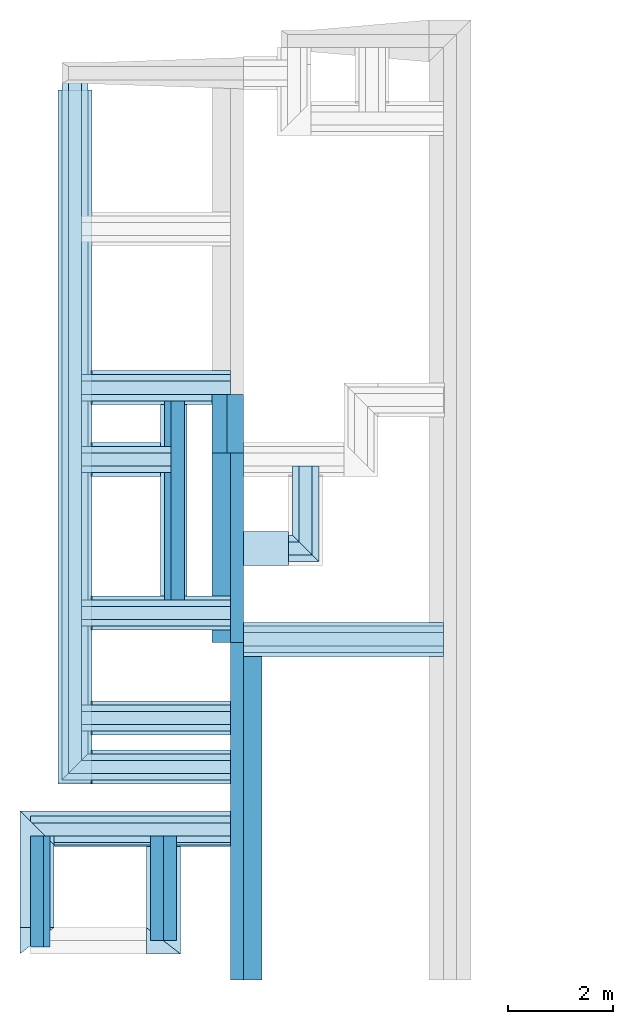
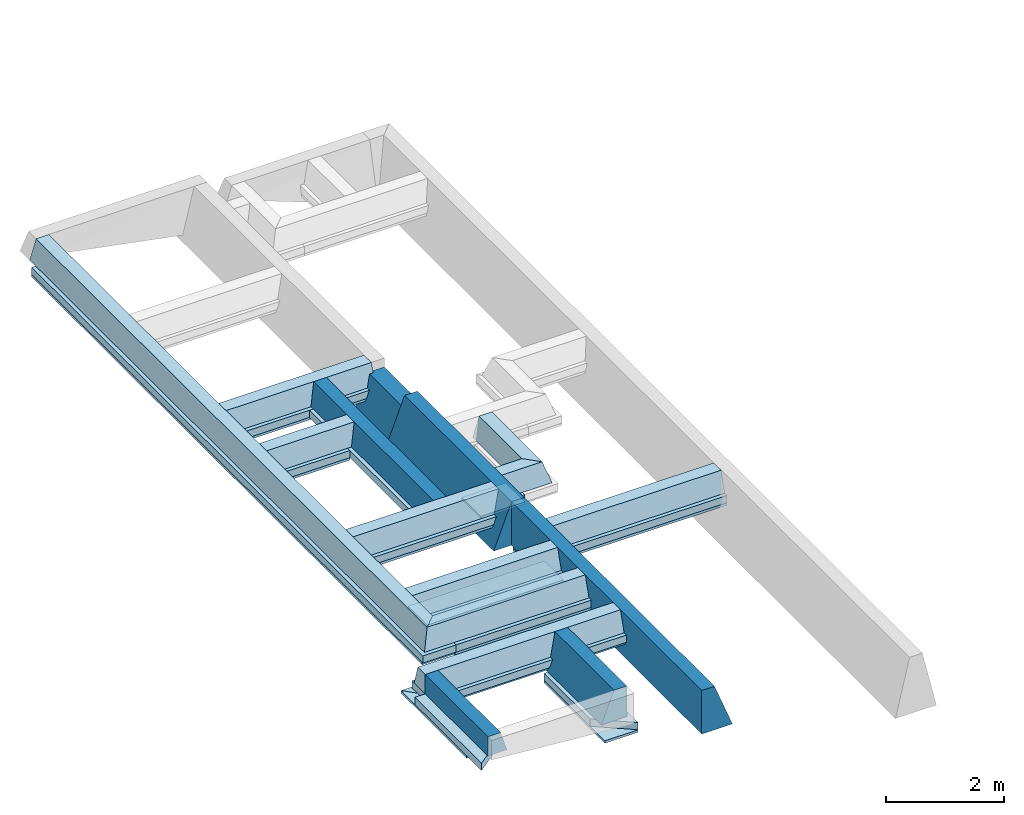
# Not in any storey, part 1 of 2: 39 footings, 1 opening.
"""IFC4 building model written with IfcOpenShell, lengths in millimetres."""

from ifc_helpers import new_model, entity, si_unit, converted_unit, frame, origin_with_axes, origin_2d_with_axis, place, context, subcontext, project, spatial, indexed_curve, rectangle, outline, extrude, clip, halfspace, material, material_profile, profile_set, profile_usage, type_object, element, save


model = new_model("IFC4")

# Units and contexts
model_context = context("Model", 3, precision=1e-05, world=origin_with_axes())
plan_context = context("Plan", 2, precision=1e-05, world=origin_2d_with_axis())
body_context = subcontext(model_context, "Body", "Model", "MODEL_VIEW")
ifc_project = project(units=[si_unit("VOLUMEUNIT", "CUBIC_METRE"), si_unit("LENGTHUNIT", "METRE", prefix="MILLI"), si_unit("AREAUNIT", "SQUARE_METRE"), converted_unit("PLANEANGLEUNIT", "degree", entity("IfcReal", 0.0174532925199433), si_unit("PLANEANGLEUNIT", "RADIAN"), dimensions=[0, 0, 0, 0, 0, 0, 0])], contexts=[model_context, plan_context])

# Site, building
site_placement = place(None, origin_with_axes())
site = spatial("IfcSite", under=ifc_project, at=site_placement)
building_1_placement = place(site_placement, origin_with_axes())
building_1 = spatial("IfcBuilding", under=site, at=building_1_placement, Name="1")

# Footings
ifc_material_1 = material()
ifc_material_profile_1 = material_profile(ifc_material_1, outline(indexed_curve([(-125.000193715096, -899.999976158142), (474.999815225601, -899.999976158142), (125.0, 0.0), (-125.0, 0.0), (-125.000193715096, -899.999976158142)])))
ifc_profile_set_1 = profile_set([ifc_material_profile_1])
ifc_profile_usage_1 = profile_usage(ifc_profile_set_1, cardinal=5)
footing_type_1 = type_object("IfcFootingType", Name="TYPE 2", PredefinedType="FOOTING_BEAM", material=ifc_profile_set_1)
footing_1_placement = place(building_1_placement, frame((-4059.99708175659, 6435.0004196167, 735.002219676971), z_axis=(-4.76837129781342e-07, -0.999999999999847, -2.82129974493684e-07), x_axis=(0.999999999999886, -4.76837129781361e-07, -3.86468829161002e-10)))
element("IfcFooting", 1, at=footing_1_placement, inside=building_1, type_object=footing_type_1, material=ifc_profile_usage_1, Name="Footing", context=body_context, shape_type="SweptSolid", body=[
    extrude(outline(indexed_curve([(-125.000193715096, -899.999976158142), (474.999815225601, -899.999976158142), (125.0, 0.0), (-125.0, 0.0), (-125.000193715096, -899.999976158142)])), origin_with_axes(), (0.0, 0.0, 1.0), 6434.9988504342),
])
ifc_profile_usage_2 = profile_usage(ifc_profile_set_1, cardinal=5)
footing_2_placement = place(building_1_placement, frame((-4059.99517440796, 6435.0004196167, 735.00382900238), z_axis=(3.89414367418746e-07, 0.999999999999875, 3.13916473260139e-07), x_axis=(-0.999999999999924, 3.89414367418765e-07, 3.8643335753538e-10)))
element("IfcFooting", 2, at=footing_2_placement, inside=building_1, type_object=footing_type_1, material=ifc_profile_usage_2, Name="Footing", context=body_context, shape_type="SweptSolid", body=[
    extrude(outline(indexed_curve([(-125.000193715096, -899.999976158142), (474.999815225601, -899.999976158142), (125.0, 0.0), (-125.0, 0.0), (-125.000193715096, -899.999976158142)])), origin_with_axes(), (0.0, 0.0, 1.0), 3619.99890216836),
])

# Footing, opening
ifc_profile_usage_3 = profile_usage(ifc_profile_set_1, cardinal=5)
footing_3_placement = place(building_1_placement, frame((-4059.99565124512, 10054.9993515015, 735.003411769867), z_axis=(3.89414367418746e-07, 0.999999999999875, 3.13916473260139e-07), x_axis=(-0.999999999999924, 3.89414367418765e-07, 3.8643335753538e-10)))
footing_3 = element("IfcFooting", 3, at=footing_3_placement, inside=building_1, type_object=footing_type_1, material=ifc_profile_usage_3, Name="Footing", context=body_context, shape_type="SweptSolid", body=[
    extrude(outline(indexed_curve([(-125.000193715096, -899.999976158142), (474.999815225601, -899.999976158142), (125.0, 0.0), (-125.0, 0.0), (-125.000193715096, -899.999976158142)])), origin_with_axes(), (0.0, 0.0, 1.0), 1120.00463663588),
])
opening_placement = place(footing_3_placement, frame((-125.000000069549, -180.00000710426, -7.82817188849094e-06), z_axis=(3.86433357535342e-10, 0.999999999999951, 3.13916473260139e-07), x_axis=(-0.999999999999924, 3.86311113950475e-10, 3.89414367540053e-07)))
element("IfcOpeningElement", 4, at=opening_placement, cuts=footing_3, Name="TYPE 2", PredefinedType="OPENING", context=body_context, shape_type="SweptSolid", body=[
    extrude(outline(indexed_curve([(-422.963287353516, 1245.00073242188), (161.13801574707, 1245.00073242188), (161.13801574707, 0.0), (-422.963287353516, 0.0), (-422.963287353516, 1245.00073242188)])), origin_with_axes(), (0.0, 0.0, 1.0), 500.0),
])

# Building
building_2_placement = place(site_placement, origin_with_axes())
building_2 = spatial("IfcBuilding", under=site, at=building_2_placement, Name="3")

# Footings
ifc_material_profile_2 = material_profile(ifc_material_1, outline(indexed_curve([(-124.999992370605, 0.0), (124.999992370605, 0.0), (374.999786376953, -629.999938964844), (-125.000183105469, -629.999938964844), (-124.999992370605, 0.0)])))
ifc_profile_set_2 = profile_set([ifc_material_profile_2])
ifc_profile_usage_4 = profile_usage(ifc_profile_set_2)
footing_type_2 = type_object("IfcFootingType", Name="TYPE 4", PredefinedType="FOOTING_BEAM", material=ifc_profile_set_2)
footing_4_placement = place(building_2_placement, frame((-5339.99586105347, 750.004649162292, 735.000252723694), z_axis=(6.27832946520202e-07, 0.999999999999754, 3.13916473260101e-07), x_axis=(-0.999999999999803, 6.27832946520233e-07, 1.20492862649261e-13)))
element("IfcFooting", 5, at=footing_4_placement, inside=building_2, type_object=footing_type_2, material=ifc_profile_usage_4, Name="Footing", context=body_context, shape_type="SweptSolid", body=[
    extrude(outline(indexed_curve([(-124.999992370605, 0.0), (124.999992370605, 0.0), (374.999786376953, -629.999938964844), (-125.000183105469, -629.999938964844), (-124.999992370605, 0.0)])), origin_with_axes(), (0.0, 0.0, 1.0), 2000.00095367471),
])
ifc_material_profile_3 = material_profile(ifc_material_1, outline(indexed_curve([(-125.000193715096, -400.000005960464), (249.999821186066, -400.000005960464), (125.0, 0.0), (-125.0, 0.0), (-125.000193715096, -400.000005960464)])))
ifc_profile_set_3 = profile_set([ifc_material_profile_3])
ifc_profile_usage_5 = profile_usage(ifc_profile_set_3, cardinal=5)
footing_type_3 = type_object("IfcFootingType", Name="TYPE 5", PredefinedType="FOOTING_BEAM", material=ifc_profile_set_3)
footing_5_placement = place(building_2_placement, frame((-7874.9942779541, 2750.00619888306, 735.000789165497), z_axis=(6.60023657906778e-15, -0.999999999999997, 7.54979012640431e-08), x_axis=(0.999999999999996, 0.0, -8.74227836789029e-08)))
element("IfcFooting", 6, at=footing_5_placement, inside=building_2, type_object=footing_type_3, material=ifc_profile_usage_5, Name="Footing", context=body_context, shape_type="SweptSolid", body=[
    extrude(outline(indexed_curve([(-125.000193715096, -400.000005960464), (249.999821186066, -400.000005960464), (125.0, 0.0), (-125.0, 0.0), (-125.000193715096, -400.000005960464)])), origin_with_axes(), (0.0, 0.0, 1.0), 2120.00158021977),
])
ifc_profile_usage_6 = profile_usage(ifc_profile_set_3, cardinal=2)
footing_6_placement = place(building_2_placement, frame((-5189.99624252319, 7125.0, 535.00097990036), z_axis=(1.50995802528084e-07, 0.999999999999986, 7.54979012640422e-08), x_axis=(-0.999999999999989, 1.50995802528085e-07, 0.0)))
element("IfcFooting", 7, at=footing_6_placement, inside=building_2, type_object=footing_type_3, material=ifc_profile_usage_6, Name="Footing", context=body_context, shape_type="SweptSolid", body=[
    extrude(outline(indexed_curve([(-125.000193715096, -400.000005960464), (249.999821186066, -400.000005960464), (125.0, 0.0), (-125.0, 0.0), (-125.000193715096, -400.000005960464)])), frame((0.0, 200.000002980232, 0.0), z_axis=(0.0, 0.0, 1.0), x_axis=(1.0, 0.0, 0.0)), (0.0, 0.0, 1.0), 4050.00496381295),
])
ifc_material_2 = material()
ifc_material_profile_4 = material_profile(ifc_material_2, rectangle(XDim=650.000061035156, YDim=150.0, kind="CURVE"))
ifc_profile_set_4 = profile_set([ifc_material_profile_4])
ifc_profile_usage_7 = profile_usage(ifc_profile_set_4, cardinal=8)
footing_type_4 = type_object("IfcFootingType", Name="60", PredefinedType="FOOTING_BEAM", material=ifc_profile_set_4)
footing_7_placement = place(building_2_placement, frame((-6824.9979019165, 11300.0049591064, 334.999740123749), z_axis=(0.999999999999932, -1.9470714107682e-07, 3.13916473260157e-07), x_axis=(1.94707183709391e-07, 0.99999999999997, -1.49011611938472e-07)))
element("IfcFooting", 8, at=footing_7_placement, inside=building_2, type_object=footing_type_4, material=ifc_profile_usage_7, Name="Footing", context=body_context, shape_type="SweptSolid", body=[
    extrude(rectangle(XDim=650.000061035156, YDim=150.0, kind="CURVE"), frame((0.0, -75.0, 0.0), z_axis=(0.0, 0.0, 1.0), x_axis=(1.0, 0.0, 0.0)), (0.0, 0.0, 1.0), 2639.93980050117),
])
ifc_profile_usage_8 = profile_usage(ifc_profile_set_4, cardinal=8)
footing_8_placement = place(building_1_placement, frame((-7150.00057220459, 3740.00477790833, 335.000157356262), z_axis=(3.89414367418746e-07, 0.999999999999875, 3.13916473260139e-07), x_axis=(-0.999999999999924, 3.89414367418765e-07, 9.83526771136592e-09)))
element("IfcFooting", 9, at=footing_8_placement, inside=building_1, type_object=footing_type_4, material=ifc_profile_usage_8, Name="Footing", context=body_context, shape_type="SweptSolid", body=[
    extrude(rectangle(XDim=650.000061035156, YDim=150.0, kind="CURVE"), frame((0.0, -75.0, 0.0), z_axis=(0.0, 0.0, 1.0), x_axis=(1.0, 0.0, 0.0)), (0.0, 0.0, 1.0), 13234.9958578192),
])
ifc_profile_usage_9 = profile_usage(ifc_profile_set_4, cardinal=8)
footing_9_placement = place(building_2_placement, frame((-6824.99980926514, 5000.00047683716, 335.000216960907), z_axis=(0.999999999999932, -1.9470714107682e-07, 3.13916473260157e-07), x_axis=(1.94707183709391e-07, 0.99999999999997, -1.49011611938472e-07)))
element("IfcFooting", 10, at=footing_9_placement, inside=building_2, type_object=footing_type_4, material=ifc_profile_usage_9, Name="Footing", context=body_context, shape_type="SweptSolid", body=[
    extrude(rectangle(XDim=650.000061035156, YDim=150.0, kind="CURVE"), frame((0.0, -75.0, 0.0), z_axis=(0.0, 0.0, 1.0), x_axis=(1.0, 0.0, 0.0)), (0.0, 0.0, 1.0), 2639.94124549468),
])
ifc_profile_usage_10 = profile_usage(ifc_profile_set_4, cardinal=8)
footing_10_placement = place(building_1_placement, frame((-6825.00076293945, 4065.00482559204, 335.000157356262), z_axis=(0.999999999999932, -1.9470714107682e-07, 3.13916473260157e-07), x_axis=(1.94707183709391e-07, 0.99999999999997, -1.49011611938472e-07)))
element("IfcFooting", 11, at=footing_10_placement, inside=building_1, type_object=footing_type_4, material=ifc_profile_usage_10, Name="Footing", context=body_context, shape_type="SweptSolid", body=[
    extrude(rectangle(XDim=650.000061035156, YDim=150.0, kind="CURVE"), frame((0.0, -75.0, 0.0), z_axis=(0.0, 0.0, 1.0), x_axis=(1.0, 0.0, 0.0)), (0.0, 0.0, 1.0), 2639.9421486153),
])
ifc_profile_usage_11 = profile_usage(ifc_profile_set_4, cardinal=8)
footing_11_placement = place(building_2_placement, frame((-6824.99980926514, 7000.00047683716, 335.000097751617), z_axis=(0.999999999999932, -1.9470714107682e-07, 3.13916473260157e-07), x_axis=(1.94707183709391e-07, 0.99999999999997, -1.49011611938472e-07)))
element("IfcFooting", 12, at=footing_11_placement, inside=building_2, type_object=footing_type_4, material=ifc_profile_usage_11, Name="Footing", context=body_context, shape_type="SweptSolid", body=[
    extrude(rectangle(XDim=650.000061035156, YDim=150.0, kind="CURVE"), frame((0.0, -75.0, 0.0), z_axis=(0.0, 0.0, 1.0), x_axis=(1.0, 0.0, 0.0)), (0.0, 0.0, 1.0), 2639.94124549468),
])
ifc_profile_usage_12 = profile_usage(ifc_profile_set_4, cardinal=8)
footing_12_placement = place(building_2_placement, frame((-6824.99980926514, 9930.00030517578, 334.999740123749), z_axis=(0.999999999999932, -1.9470714107682e-07, 3.13916473260157e-07), x_axis=(1.94707183709391e-07, 0.99999999999997, -1.49011611938472e-07)))
element("IfcFooting", 13, at=footing_12_placement, inside=building_2, type_object=footing_type_4, material=ifc_profile_usage_12, Name="Footing", context=body_context, shape_type="SweptSolid", body=[
    extrude(rectangle(XDim=650.000061035156, YDim=150.0, kind="CURVE"), frame((0.0, -75.0, 0.0), z_axis=(0.0, 0.0, 1.0), x_axis=(1.0, 0.0, 0.0)), (0.0, 0.0, 1.0), 1310.00422287769),
])

# Building
building_3_placement = place(site_placement, origin_with_axes())
building_3 = spatial("IfcBuilding", under=site, at=building_3_placement, Name="2")

# Footings
ifc_profile_usage_13 = profile_usage(ifc_profile_set_4, cardinal=8)
footing_13_placement = place(building_3_placement, frame((-3934.99779701233, 6500.00047683716, -400.000631809235), z_axis=(0.999999999999932, -1.9470714107682e-07, 3.13916473260157e-07), x_axis=(1.94707183709391e-07, 0.99999999999997, -1.49011611938472e-07)))
element("IfcFooting", 14, at=footing_13_placement, inside=building_3, type_object=footing_type_4, material=ifc_profile_usage_13, Name="Footing", context=body_context, shape_type="SweptSolid", body=[
    extrude(rectangle(XDim=650.000061035156, YDim=150.0, kind="CURVE"), frame((0.0, -75.0, 0.0), z_axis=(0.0, 0.0, 1.0), x_axis=(1.0, 0.0, 0.0)), (0.0, 0.0, 1.0), 3809.99873924766),
])
ifc_profile_usage_14 = profile_usage(ifc_profile_set_4, cardinal=8)
footing_14_placement = place(building_3_placement, frame((-3934.99803543091, 8230.00144958496, -400.00057220459), z_axis=(0.999999999999932, -1.9470714107682e-07, 3.13916473260157e-07), x_axis=(1.94707183709391e-07, 0.99999999999997, -1.49011611938472e-07)))
element("IfcFooting", 15, at=footing_14_placement, inside=building_3, type_object=footing_type_4, material=ifc_profile_usage_14, Name="Footing", context=body_context, shape_type="SweptSolid", body=[
    extrude(rectangle(XDim=650.000061035156, YDim=150.0, kind="CURVE"), frame((0.0, -75.0, 0.0), z_axis=(0.0, 0.0, 1.0), x_axis=(1.0, 0.0, 0.0)), (0.0, 0.0, 1.0), 860.00298183505),
])
ifc_profile_usage_15 = profile_usage(ifc_profile_set_4, cardinal=8)
footing_15_placement = place(building_2_placement, frame((-7999.9942779541, 2875.00619888306, 334.999769926071), z_axis=(0.999999999999932, -1.9470714107682e-07, 3.13916473260157e-07), x_axis=(1.94707183709391e-07, 0.99999999999997, -1.49011611938472e-07)))
element("IfcFooting", 16, at=footing_15_placement, inside=building_2, type_object=footing_type_4, material=ifc_profile_usage_15, Name="Footing", context=body_context, shape_type="SweptSolid", body=[
    extrude(rectangle(XDim=650.000061035156, YDim=150.0, kind="CURVE"), frame((0.0, -75.0, 0.0), z_axis=(0.0, 0.0, 1.0), x_axis=(1.0, 0.0, 0.0)), (0.0, 0.0, 1.0), 3814.93562536585),
])
ifc_profile_usage_16 = profile_usage(ifc_profile_set_4, cardinal=8)
footing_16_placement = place(building_2_placement, frame((-5464.99586105347, 500.004887580872, 105.000235140324), z_axis=(6.27832946520202e-07, 0.999999999999754, 3.13916473260101e-07), x_axis=(-0.999999999999803, 6.27832946520233e-07, 1.20492862649261e-13)))
element("IfcFooting", 17, at=footing_16_placement, inside=building_2, type_object=footing_type_4, material=ifc_profile_usage_16, Name="Footing", context=body_context, shape_type="Clipping", body=[
    clip(extrude(rectangle(XDim=650.000061035156, YDim=150.0, kind="CURVE"), frame((0.0, -75.0, 0.0), z_axis=(0.0, 0.0, 1.0), x_axis=(1.0, 0.0, 0.0)), (0.0, 0.0, 1.0), 2049.96635595519), halfspace(frame((-324.999958276749, -105.00019043684, 0.000230010542168202), z_axis=(0.609710335731506, 1.77951690716327e-07, -0.792624235153198), x_axis=(2.91862676893643e-07, -0.999999999999957, 0.0)), False)),
])
ifc_profile_usage_17 = profile_usage(ifc_profile_set_4, cardinal=8)
footing_17_placement = place(building_2_placement, frame((-7874.9942779541, 2750.00619888306, 335.000842809677), z_axis=(6.60023657906778e-15, -0.999999999999997, 7.54979012640431e-08), x_axis=(0.999999999999996, 0.0, -8.74227836789029e-08)))
element("IfcFooting", 18, at=footing_17_placement, inside=building_2, type_object=footing_type_4, material=ifc_profile_usage_17, Name="Footing", context=body_context, shape_type="Clipping", body=[
    clip(extrude(rectangle(XDim=650.000061035156, YDim=150.0, kind="CURVE"), frame((0.0, -75.0, 0.0), z_axis=(0.0, 0.0, 1.0), x_axis=(1.0, 0.0, 0.0)), (0.0, 0.0, 1.0), 2250.00211927527), halfspace(frame((-324.99885559082, -335.000276565552, 2250.00238418579), z_axis=(0.609711706638336, -1.30707405787689e-07, 0.792623221874237), x_axis=(-2.14375752285199e-07, -0.999999999999977, 0.0)), False)),
])
ifc_material_profile_5 = material_profile(ifc_material_1, outline(indexed_curve([(-124.999992370605, 0.0), (124.999992370605, 0.0), (249.999984741211, -399.999969482422), (-249.999984741211, -399.999969482422), (-124.999992370605, 0.0)])))
ifc_profile_set_5 = profile_set([ifc_material_profile_5])
ifc_profile_usage_18 = profile_usage(ifc_profile_set_5)
footing_type_5 = type_object("IfcFootingType", Name="TYPE 3", PredefinedType="FOOTING_BEAM", material=ifc_profile_set_5)
footing_18_placement = place(building_1_placement, frame((-7150.00057220459, 3815.00482559204, 735.000133514404), z_axis=(3.89414367418746e-07, 0.999999999999875, 3.13916473260139e-07), x_axis=(-0.999999999999924, 3.89414367418765e-07, 9.83526771136592e-09)))
element("IfcFooting", 19, at=footing_18_placement, inside=building_1, type_object=footing_type_5, material=ifc_profile_usage_18, Name="Footing", context=body_context, shape_type="Clipping", body=[
    clip(extrude(outline(indexed_curve([(-124.999992370605, 0.0), (124.999992370605, 0.0), (249.999984741211, -399.999969482422), (-249.999984741211, -399.999969482422), (-124.999992370605, 0.0)])), origin_with_axes(), (0.0, 0.0, 1.0), 13359.9969016448), halfspace(frame((250.000059604645, -735.000550746918, -0.000259062176155567), z_axis=(-0.707106411457062, 3.06266315419634e-07, -0.707107126712799), x_axis=(4.33126203435935e-07, 0.999999999999906, 0.0)), False)),
])
ifc_profile_usage_19 = profile_usage(ifc_profile_set_5)
footing_19_placement = place(building_1_placement, frame((-7400.00057220459, 4065.00482559204, 734.99995470047), z_axis=(0.999999999999932, -1.9470714107682e-07, 3.13916473260157e-07), x_axis=(1.94707183709391e-07, 0.99999999999997, -1.49011611938472e-07)))
element("IfcFooting", 20, at=footing_19_placement, inside=building_1, type_object=footing_type_5, material=ifc_profile_usage_19, Name="Footing", context=body_context, shape_type="Clipping", body=[
    clip(extrude(outline(indexed_curve([(-124.999992370605, 0.0), (124.999992370605, 0.0), (249.999984741211, -399.999969482422), (-249.999984741211, -399.999969482422), (-124.999992370605, 0.0)])), origin_with_axes(), (0.0, 0.0, 1.0), 3214.94193871566), halfspace(frame((-250.0, -735.000371932983, 0.00021086549395477), z_axis=(0.707107305526733, 2.50000340429324e-07, -0.707106232643127), x_axis=(3.53553609862763e-07, -0.999999999999937, 0.0)), False)),
])
ifc_profile_usage_20 = profile_usage(ifc_profile_set_5)
footing_20_placement = place(building_2_placement, frame((-7024.99961853027, 5000.00047683716, 735.00007390976), z_axis=(0.999999999999932, -1.9470714107682e-07, 3.13916473260157e-07), x_axis=(1.94707183709391e-07, 0.99999999999997, -1.49011611938472e-07)))
element("IfcFooting", 21, at=footing_20_placement, inside=building_2, type_object=footing_type_5, material=ifc_profile_usage_20, Name="Footing", context=body_context, shape_type="SweptSolid", body=[
    extrude(outline(indexed_curve([(-124.999992370605, 0.0), (124.999992370605, 0.0), (249.999984741211, -399.999969482422), (-249.999984741211, -399.999969482422), (-124.999992370605, 0.0)])), origin_with_axes(), (0.0, 0.0, 1.0), 2839.94096802104),
])
ifc_profile_usage_21 = profile_usage(ifc_profile_set_5)
footing_21_placement = place(building_2_placement, frame((-7024.99914169312, 7000.00047683716, 735.000014305115), z_axis=(0.999999999999932, -1.9470714107682e-07, 3.13916473260157e-07), x_axis=(1.94707183709391e-07, 0.99999999999997, -1.49011611938472e-07)))
element("IfcFooting", 22, at=footing_21_placement, inside=building_2, type_object=footing_type_5, material=ifc_profile_usage_21, Name="Footing", context=body_context, shape_type="SweptSolid", body=[
    extrude(outline(indexed_curve([(-124.999992370605, 0.0), (124.999992370605, 0.0), (249.999984741211, -399.999969482422), (-249.999984741211, -399.999969482422), (-124.999992370605, 0.0)])), origin_with_axes(), (0.0, 0.0, 1.0), 2839.9404643093),
])
ifc_profile_usage_22 = profile_usage(ifc_profile_set_5)
footing_22_placement = place(building_3_placement, frame((-3934.99779701233, 6500.00047683716, -0.000645680642975321), z_axis=(0.999999999999932, -1.9470714107682e-07, 3.13916473260157e-07), x_axis=(1.94707183709391e-07, 0.99999999999997, -1.49011611938472e-07)))
element("IfcFooting", 23, at=footing_22_placement, inside=building_3, type_object=footing_type_5, material=ifc_profile_usage_22, Name="Footing", context=body_context, shape_type="SweptSolid", body=[
    extrude(outline(indexed_curve([(-124.999992370605, 0.0), (124.999992370605, 0.0), (249.999984741211, -399.999969482422), (-249.999984741211, -399.999969482422), (-124.999992370605, 0.0)])), origin_with_axes(), (0.0, 0.0, 1.0), 3809.99873924766),
])
ifc_profile_usage_23 = profile_usage(ifc_profile_set_5)
footing_23_placement = place(building_3_placement, frame((-3934.99803543091, 8230.00144958496, -0.00060644123297493), z_axis=(0.999999999999932, -1.9470714107682e-07, 3.13916473260157e-07), x_axis=(1.94707183709391e-07, 0.99999999999997, -1.49011611938472e-07)))
element("IfcFooting", 24, at=footing_23_placement, inside=building_3, type_object=footing_type_5, material=ifc_profile_usage_23, Name="Footing", context=body_context, shape_type="Clipping", body=[
    clip(extrude(outline(indexed_curve([(-124.999992370605, 0.0), (124.999992370605, 0.0), (249.999984741211, -399.999969482422), (-249.999984741211, -399.999969482422), (-124.999992370605, 0.0)])), origin_with_axes(), (0.0, 0.0, 1.0), 1435.00277010561), halfspace(frame((-250.0, -0.000859446799950092, 1435.00316143036), z_axis=(0.707106530666351, -1.93298006934128e-07, 0.707106947898865), x_axis=(-2.73364759836066e-07, -0.999999999999963, 0.0)), False)),
])
ifc_profile_usage_24 = profile_usage(ifc_profile_set_5)
footing_24_placement = place(building_3_placement, frame((-2749.99523162842, 7980.0009727478, -0.000230635521347722), z_axis=(1.50995802528084e-07, 0.999999999999986, 7.54979012640422e-08), x_axis=(-0.999999999999988, 1.50995802528085e-07, -1.07495621293195e-08)))
element("IfcFooting", 25, at=footing_24_placement, inside=building_3, type_object=footing_type_5, material=ifc_profile_usage_24, Name="Footing", context=body_context, shape_type="Clipping", body=[
    clip(extrude(outline(indexed_curve([(-124.999992370605, 0.0), (124.999992370605, 0.0), (249.999984741211, -399.999969482422), (-249.999984741211, -399.999969482422), (-124.999992370605, 0.0)])), origin_with_axes(), (0.0, 0.0, 1.0), 1825.00027695747), halfspace(frame((-250.000238418579, -0.000750216031519813, 9.93483268985074e-05), z_axis=(0.707106947898865, 1.37678725309343e-07, -0.707106530666351), x_axis=(1.94707074677241e-07, -0.999999999999981, 0.0)), False)),
])
ifc_profile_usage_25 = profile_usage(ifc_profile_set_5)
footing_25_placement = place(building_2_placement, frame((-7024.9981880188, 9930.00030517578, 734.999597072601), z_axis=(0.999999999999932, -1.9470714107682e-07, 3.13916473260157e-07), x_axis=(1.94707183709391e-07, 0.99999999999997, -1.49011611938472e-07)))
element("IfcFooting", 26, at=footing_25_placement, inside=building_2, type_object=footing_type_5, material=ifc_profile_usage_25, Name="Footing", context=body_context, shape_type="SweptSolid", body=[
    extrude(outline(indexed_curve([(-124.999992370605, 0.0), (124.999992370605, 0.0), (249.999984741211, -399.999969482422), (-249.999984741211, -399.999969482422), (-124.999992370605, 0.0)])), origin_with_axes(), (0.0, 0.0, 1.0), 1710.00241720026),
])
ifc_profile_usage_26 = profile_usage(ifc_profile_set_5)
footing_26_placement = place(building_2_placement, frame((-7024.99771118164, 11300.0049591064, 734.999597072601), z_axis=(0.999999999999932, -1.9470714107682e-07, 3.13916473260157e-07), x_axis=(1.94707183709391e-07, 0.99999999999997, -1.49011611938472e-07)))
element("IfcFooting", 27, at=footing_26_placement, inside=building_2, type_object=footing_type_5, material=ifc_profile_usage_26, Name="Footing", context=body_context, shape_type="SweptSolid", body=[
    extrude(outline(indexed_curve([(-124.999992370605, 0.0), (124.999992370605, 0.0), (249.999984741211, -399.999969482422), (-249.999984741211, -399.999969482422), (-124.999992370605, 0.0)])), origin_with_axes(), (0.0, 0.0, 1.0), 2839.93962478966),
])
ifc_profile_usage_27 = profile_usage(ifc_profile_set_5)
footing_27_placement = place(building_2_placement, frame((-7999.9942779541, 2875.00619888306, 734.999716281891), z_axis=(0.999999999999932, -1.9470714107682e-07, 3.13916473260157e-07), x_axis=(1.94707183709391e-07, 0.99999999999997, -1.49011611938472e-07)))
element("IfcFooting", 28, at=footing_27_placement, inside=building_2, type_object=footing_type_5, material=ifc_profile_usage_27, Name="Footing", context=body_context, shape_type="SweptSolid", body=[
    extrude(outline(indexed_curve([(-124.999992370605, 0.0), (124.999992370605, 0.0), (249.999984741211, -399.999969482422), (-249.999984741211, -399.999969482422), (-124.999992370605, 0.0)])), origin_with_axes(), (0.0, 0.0, 1.0), 3814.93562536585),
])
ifc_material_profile_6 = material_profile(ifc_material_2, rectangle(XDim=500.0, YDim=150.0, kind="CURVE"))
ifc_profile_set_6 = profile_set([ifc_material_profile_6])
ifc_profile_usage_28 = profile_usage(ifc_profile_set_6)
footing_type_6 = type_object("IfcFootingType", Name="50", PredefinedType="FOOTING_BEAM", material=ifc_profile_set_6)
footing_28_placement = place(building_2_placement, frame((-5264.99605178833, 7324.99980926514, 260.000973939896), z_axis=(1.50995802528084e-07, 0.999999999999986, 7.54979012640422e-08), x_axis=(-0.999999999999989, 1.50995802528085e-07, 0.0)))
element("IfcFooting", 29, at=footing_28_placement, inside=building_2, type_object=footing_type_6, material=ifc_profile_usage_28, Name="Footing", context=body_context, shape_type="SweptSolid", body=[
    extrude(rectangle(XDim=500.0, YDim=150.0, kind="CURVE"), origin_with_axes(), (0.0, 0.0, 1.0), 3650.00434248161),
])
ifc_material_3 = material()
ifc_material_profile_7 = material_profile(ifc_material_3, rectangle(XDim=650.000061035156, YDim=50.0, kind="CURVE"))
ifc_profile_set_7 = profile_set([ifc_material_profile_7])
ifc_profile_usage_29 = profile_usage(ifc_profile_set_7, cardinal=8)
footing_type_7 = type_object("IfcFootingType", Name="60", PredefinedType="FOOTING_BEAM", material=ifc_profile_set_7)
footing_29_placement = place(building_2_placement, frame((-6849.99990463257, 9930.00030517578, 184.999465942383), z_axis=(0.999999999999932, -1.9470714107682e-07, 3.13916473260157e-07), x_axis=(1.94707183709391e-07, 0.99999999999997, -1.49011611938472e-07)))
element("IfcFooting", 30, at=footing_29_placement, inside=building_2, type_object=footing_type_7, material=ifc_profile_usage_29, Name="Footing", context=body_context, shape_type="SweptSolid", body=[
    extrude(rectangle(XDim=650.000061035156, YDim=50.0, kind="CURVE"), frame((0.0, -25.0, 0.0), z_axis=(0.0, 0.0, 1.0), x_axis=(1.0, 0.0, 0.0)), (0.0, 0.0, 1.0), 1335.00433560363),
])
ifc_profile_usage_30 = profile_usage(ifc_profile_set_7, cardinal=8)
footing_30_placement = place(building_3_placement, frame((-3934.99779701233, 6500.00047683716, -550.000905990601), z_axis=(0.999999999999932, -1.9470714107682e-07, 3.13916473260157e-07), x_axis=(1.94707183709391e-07, 0.99999999999997, -1.49011611938472e-07)))
element("IfcFooting", 31, at=footing_30_placement, inside=building_3, type_object=footing_type_7, material=ifc_profile_usage_30, Name="Footing", context=body_context, shape_type="SweptSolid", body=[
    extrude(rectangle(XDim=650.000061035156, YDim=50.0, kind="CURVE"), frame((0.0, -25.0, 0.0), z_axis=(0.0, 0.0, 1.0), x_axis=(1.0, 0.0, 0.0)), (0.0, 0.0, 1.0), 3809.99873924766),
])
ifc_profile_usage_31 = profile_usage(ifc_profile_set_7, cardinal=8)
footing_31_placement = place(building_1_placement, frame((-7150.00057220459, 3765.00487327576, 185.00018119812), z_axis=(3.89414367418746e-07, 0.999999999999875, 3.13916473260139e-07), x_axis=(-0.999999999999924, 3.89414367418765e-07, 9.83526771136592e-09)))
element("IfcFooting", 32, at=footing_31_placement, inside=building_1, type_object=footing_type_7, material=ifc_profile_usage_31, Name="Footing", context=body_context, shape_type="SweptSolid", body=[
    extrude(rectangle(XDim=650.000061035156, YDim=50.0, kind="CURVE"), frame((0.0, -25.0, 0.0), z_axis=(0.0, 0.0, 1.0), x_axis=(1.0, 0.0, 0.0)), (0.0, 0.0, 1.0), 13209.9955542759),
])
ifc_profile_usage_32 = profile_usage(ifc_profile_set_7, cardinal=8)
footing_32_placement = place(building_1_placement, frame((-6850.00038146973, 4065.00482559204, 185.00018119812), z_axis=(0.999999999999932, -1.9470714107682e-07, 3.13916473260157e-07), x_axis=(1.94707183709391e-07, 0.99999999999997, -1.49011611938472e-07)))
element("IfcFooting", 33, at=footing_32_placement, inside=building_1, type_object=footing_type_7, material=ifc_profile_usage_32, Name="Footing", context=body_context, shape_type="SweptSolid", body=[
    extrude(rectangle(XDim=650.000061035156, YDim=50.0, kind="CURVE"), frame((0.0, -25.0, 0.0), z_axis=(0.0, 0.0, 1.0), x_axis=(1.0, 0.0, 0.0)), (0.0, 0.0, 1.0), 2664.94181599915),
])
ifc_profile_usage_33 = profile_usage(ifc_profile_set_7, cardinal=8)
footing_33_placement = place(building_2_placement, frame((-6849.99990463257, 5000.00047683716, 185.00018119812), z_axis=(0.999999999999932, -1.9470714107682e-07, 3.13916473260157e-07), x_axis=(1.94707183709391e-07, 0.99999999999997, -1.49011611938472e-07)))
element("IfcFooting", 34, at=footing_33_placement, inside=building_2, type_object=footing_type_7, material=ifc_profile_usage_33, Name="Footing", context=body_context, shape_type="SweptSolid", body=[
    extrude(rectangle(XDim=650.000061035156, YDim=50.0, kind="CURVE"), frame((0.0, -25.0, 0.0), z_axis=(0.0, 0.0, 1.0), x_axis=(1.0, 0.0, 0.0)), (0.0, 0.0, 1.0), 2664.94127921009),
])
ifc_profile_usage_34 = profile_usage(ifc_profile_set_7, cardinal=8)
footing_34_placement = place(building_2_placement, frame((-5464.99586105347, 500.004470348358, -45.0000762939453), z_axis=(6.27832946520202e-07, 0.999999999999754, 3.13916473260101e-07), x_axis=(-0.999999999999803, 6.27832946520233e-07, 1.20492862649261e-13)))
element("IfcFooting", 35, at=footing_34_placement, inside=building_2, type_object=footing_type_7, material=ifc_profile_usage_34, Name="Footing", context=body_context, shape_type="SweptSolid", body=[
    extrude(rectangle(XDim=650.000061035156, YDim=50.0, kind="CURVE"), frame((0.0, -25.0, 0.0), z_axis=(0.0, 0.0, 1.0), x_axis=(1.0, 0.0, 0.0)), (0.0, 0.0, 1.0), 2049.96682117003),
])
ifc_profile_usage_35 = profile_usage(ifc_profile_set_7, cardinal=8)
footing_35_placement = place(building_2_placement, frame((-7874.9942779541, 3225.0063419342, 185.00080704689), z_axis=(6.60023657906778e-15, -0.999999999999997, 7.54979012640431e-08), x_axis=(0.999999999999996, 0.0, -8.74227836789029e-08)))
element("IfcFooting", 36, at=footing_35_placement, inside=building_2, type_object=footing_type_7, material=ifc_profile_usage_35, Name="Footing", context=body_context, shape_type="Clipping", body=[
    clip(extrude(rectangle(XDim=650.000061035156, YDim=50.0, kind="CURVE"), frame((0.0, -25.0, 0.0), z_axis=(0.0, 0.0, 1.0), x_axis=(1.0, 0.0, 0.0)), (0.0, 0.0, 1.0), 2225.00223738312), halfspace(frame((-324.99885559082, -185.000494122505, -2.88657986402541e-11), z_axis=(0.707107543945312, -3.09085770311412e-08, -0.707105994224548), x_axis=(-4.37112816795682e-08, -0.999999999999999, 0.0)), False)),
])
ifc_profile_usage_36 = profile_usage(ifc_profile_set_7, cardinal=8)
footing_36_placement = place(building_2_placement, frame((-6849.99990463257, 7000.00047683716, 184.999942779541), z_axis=(0.999999999999932, -1.9470714107682e-07, 3.13916473260157e-07), x_axis=(1.94707183709391e-07, 0.99999999999997, -1.49011611938472e-07)))
element("IfcFooting", 37, at=footing_36_placement, inside=building_2, type_object=footing_type_7, material=ifc_profile_usage_36, Name="Footing", context=body_context, shape_type="SweptSolid", body=[
    extrude(rectangle(XDim=650.000061035156, YDim=50.0, kind="CURVE"), frame((0.0, -25.0, 0.0), z_axis=(0.0, 0.0, 1.0), x_axis=(1.0, 0.0, 0.0)), (0.0, 0.0, 1.0), 2664.94127921009),
])
ifc_profile_usage_37 = profile_usage(ifc_profile_set_7, cardinal=8)
footing_37_placement = place(building_2_placement, frame((-8199.99408721924, 2900.00629425049, 184.999704360962), z_axis=(0.999999999999932, -1.9470714107682e-07, 3.13916473260157e-07), x_axis=(1.94707183709391e-07, 0.99999999999997, -1.49011611938472e-07)))
element("IfcFooting", 38, at=footing_37_placement, inside=building_2, type_object=footing_type_7, material=ifc_profile_usage_37, Name="Footing", context=body_context, shape_type="Clipping", body=[
    clip(extrude(rectangle(XDim=650.000061035156, YDim=50.0, kind="CURVE"), frame((0.0, -25.0, 0.0), z_axis=(0.0, 0.0, 1.0), x_axis=(1.0, 0.0, 0.0)), (0.0, 0.0, 1.0), 4014.93550478037), halfspace(frame((325.000107288361, -184.999331831932, 0.001279417006117), z_axis=(-0.707106113433838, 2.62716554289e-07, -0.707107424736023), x_axis=(3.71537664995119e-07, 0.999999999999931, 0.0)), False)),
])
ifc_profile_usage_38 = profile_usage(ifc_profile_set_7, cardinal=8)
footing_38_placement = place(building_3_placement, frame((-3934.99803543091, 8230.00144958496, -550.000667572021), z_axis=(0.999999999999932, -1.9470714107682e-07, 3.13916473260157e-07), x_axis=(1.94707183709391e-07, 0.99999999999997, -1.49011611938472e-07)))
element("IfcFooting", 39, at=footing_38_placement, inside=building_3, type_object=footing_type_7, material=ifc_profile_usage_38, Name="Footing", context=body_context, shape_type="SweptSolid", body=[
    extrude(rectangle(XDim=650.000061035156, YDim=50.0, kind="CURVE"), frame((0.0, -25.0, 0.0), z_axis=(0.0, 0.0, 1.0), x_axis=(1.0, 0.0, 0.0)), (0.0, 0.0, 1.0), 860.002739258824),
])
ifc_profile_usage_39 = profile_usage(ifc_profile_set_7, cardinal=8)
footing_39_placement = place(building_2_placement, frame((-6849.99799728394, 11300.0049591064, 184.999465942383), z_axis=(0.999999999999932, -1.9470714107682e-07, 3.13916473260157e-07), x_axis=(1.94707183709391e-07, 0.99999999999997, -1.49011611938472e-07)))
element("IfcFooting", 40, at=footing_39_placement, inside=building_2, type_object=footing_type_7, material=ifc_profile_usage_39, Name="Footing", context=body_context, shape_type="SweptSolid", body=[
    extrude(rectangle(XDim=650.000061035156, YDim=50.0, kind="CURVE"), frame((0.0, -25.0, 0.0), z_axis=(0.0, 0.0, 1.0), x_axis=(1.0, 0.0, 0.0)), (0.0, 0.0, 1.0), 2664.93984777219),
])

save(model, "model.ifc")
